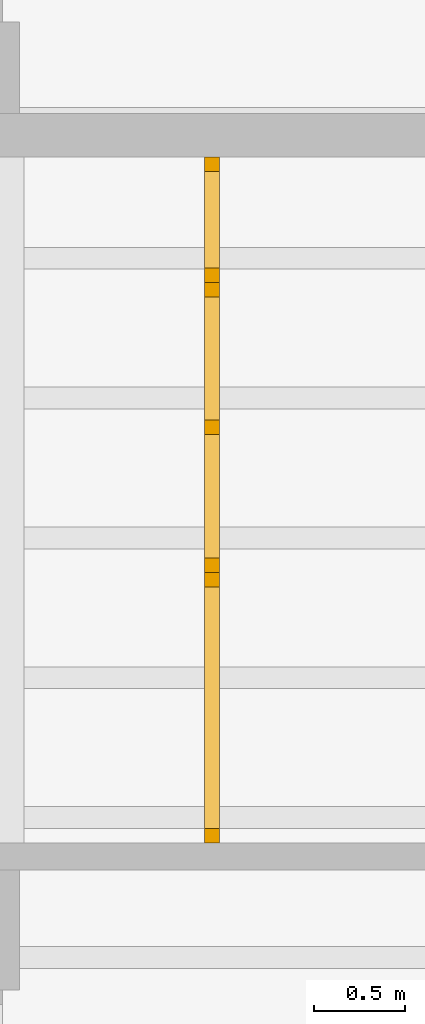
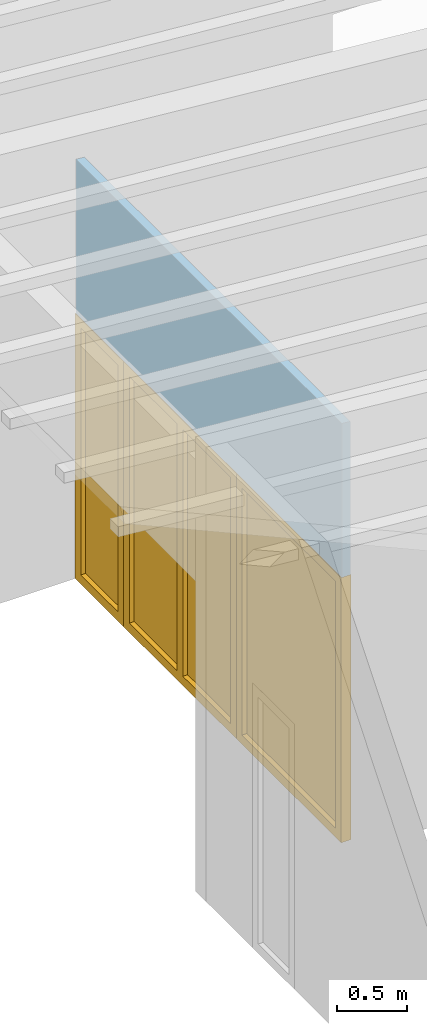
# One storey, part 6 of 13: 2 doors, 1 window, 3 openings, plus 1 element that does not belong to this part.
"""IFC2X3 building model written with IfcOpenShell, lengths in millimetres."""

from ifc_helpers import new_model, entity, si_unit, converted_unit, frame, frame_2d, origin, origin_with_axes, place, context, project, spatial, rectangle, extrude, clip, halfspace, faceted_brep, material, layer, layer_set, layer_usage, type_object, element, fill, save


model = new_model("IFC2X3")

# Units and contexts
model_context = context("Model", 3, precision=1e-05, world=origin())
plan_context = context("Plan", 3, precision=1e-05, world=origin())
ifc_project = project(units=[si_unit("LENGTHUNIT", "METRE", prefix="MILLI"), converted_unit("PLANEANGLEUNIT", "DEGREE", entity("IfcPlaneAngleMeasure", 0.0174532925199433), si_unit("PLANEANGLEUNIT", "RADIAN"), dimensions=[0, 0, 0, 0, 0, 0, 0]), si_unit("AREAUNIT", "SQUARE_METRE"), si_unit("VOLUMEUNIT", "CUBIC_METRE")], contexts=[model_context, plan_context])

# Building, storey
building_placement = place(None, origin())
building = spatial("IfcBuilding", under=ifc_project, at=building_placement, CompositionType="ELEMENT")
storey_placement = place(building_placement, frame((0.0, 0.0, 4770.0), z_axis=(0.0, 0.0, 1.0), x_axis=(1.0, 0.0, 0.0)))
storey = spatial("IfcBuildingStorey", under=building, at=storey_placement, Name="Geschoss", CompositionType="ELEMENT", Elevation=4770.0)

# Wall, openings, doors, window
ifc_material_1 = material(Name="glas")
ifc_layer = layer(ifc_material_1, 70.0)
ifc_layer_set = layer_set([ifc_layer])
ifc_layer_usage = layer_usage(ifc_layer_set, "AXIS2", "POSITIVE", 0.0)
wall_placement = place(storey_placement, frame((22458.3517822139, -4591.5625, 0.0), z_axis=(0.0, 0.0, 1.0), x_axis=(0.0, 1.0, 0.0)))
wall = element("IfcWallStandardCase", 1, at=wall_placement, inside=storey, material=ifc_layer_usage, context=model_context, shape_type="Clipping", body=[
    clip(extrude(rectangle(XDim=3780.0, YDim=70.0, at=frame_2d((1890.0, 35.0), x_axis=(1.0, 0.0))), origin_with_axes(), (0.0, 0.0, 1.0), 3635.62189784294), halfspace(frame((0.0, 0.0, 3629.49769139612), z_axis=(0.0, 0.0871557427476648, -0.996194698091745), x_axis=(1.0, 0.0, 0.0)), True)),
])
opening_1_placement = place(wall_placement, frame((3090.0, 0.0, 0.0), z_axis=(0.0, 1.0, 0.0), x_axis=(0.0, 0.0, 1.0)))
opening_1 = element("IfcOpeningElement", 2, at=opening_1_placement, cuts=wall, ObjectType="Opening", context=model_context, shape_type="SweptSolid", body=[
    extrude(rectangle(XDim=2300.0, YDim=689.999999999996, at=frame_2d((1150.0, 344.999999999998), x_axis=(1.0, 0.0))), origin_with_axes(), (0.0, 0.0, 1.0), 70.0),
])
opening_2_placement = place(wall_placement, frame((0.0, 0.0, 0.0), z_axis=(0.0, 1.0, 0.0), x_axis=(0.0, 0.0, 1.0)))
opening_2 = element("IfcOpeningElement", 3, at=opening_2_placement, cuts=wall, ObjectType="Opening", context=model_context, shape_type="SweptSolid", body=[
    extrude(rectangle(XDim=2300.0, YDim=1490.0, at=frame_2d((1150.0, 745.0), x_axis=(1.0, 0.0))), origin_with_axes(), (0.0, 0.0, 1.0), 70.0),
])
opening_3_placement = place(wall_placement, frame((1490.0, 0.0, 0.0), z_axis=(0.0, 1.0, 0.0), x_axis=(0.0, 0.0, 1.0)))
opening_3 = element("IfcOpeningElement", 4, at=opening_3_placement, cuts=wall, ObjectType="Opening", context=model_context, shape_type="SweptSolid", body=[
    extrude(rectangle(XDim=2300.0, YDim=1600.0, at=frame_2d((1150.0, 800.0), x_axis=(1.0, 0.0))), origin_with_axes(), (0.0, 0.0, 1.0), 70.0),
])
ifc_material_2 = material()
door_style_1 = type_object("IfcDoorStyle", Name="Verglasung 01", ConstructionType="NOTDEFINED", OperationType="USERDEFINED", ParameterTakesPrecedence=False, Sizeable=False)
door_1_placement = place(opening_1_placement, frame((0.0, 0.0, 0.0), z_axis=(1.0, 0.0, 0.0), x_axis=(0.0, 1.0, 0.0)))
door_1 = element("IfcDoor", 5, at=door_1_placement, inside=storey, type_object=door_style_1, material=ifc_material_2, Name="Verglasung 01", OverallHeight=2300.0, OverallWidth=690.0, context=model_context, shape_type="Brep", body=[
    faceted_brep([(609.999999999996, 75.0000000000014, 0.0), (689.999999999996, 75.0000000000014, 0.0), (689.999999999996, 75.0000000000014, 2300.0), (609.999999999996, 75.0000000000014, 2300.0), (689.999999999996, -4.99999999999859, 0.0), (609.999999999996, -4.99999999999859, 0.0), (609.999999999996, -4.99999999999859, 2300.0), (689.999999999996, -4.99999999999859, 2300.0), (689.999999999996, 75.0000000000014, 0.0), (609.999999999996, 75.0000000000014, 0.0), (609.999999999996, -4.99999999999859, 0.0), (689.999999999996, -4.99999999999859, 0.0), (689.999999999996, 75.0000000000014, 2300.0), (689.999999999996, 75.0000000000014, 0.0), (689.999999999996, -4.99999999999859, 0.0), (689.999999999996, -4.99999999999859, 2300.0), (609.999999999996, 75.0000000000014, 2300.0), (689.999999999996, 75.0000000000014, 2300.0), (689.999999999996, -4.99999999999859, 2300.0), (609.999999999996, -4.99999999999859, 2300.0), (609.999999999996, 75.0000000000014, 0.0), (609.999999999996, 75.0000000000014, 2300.0), (609.999999999996, -4.99999999999859, 2300.0), (609.999999999996, -4.99999999999859, 0.0)], [[[0, 1, 2, 3]], [[4, 5, 6, 7]], [[8, 9, 10, 11]], [[12, 13, 14, 15]], [[16, 17, 18, 19]], [[20, 21, 22, 23]]], orient=[[False], [False], [False], [False], [False], [False]]),
    faceted_brep([(80.0, 75.0000000000015, 2300.0), (3.34279265644953e-16, 75.0000000000015, 2300.0), (3.34279265644953e-16, 75.0000000000015, 0.0), (80.0, 75.0000000000015, 0.0), (-4.56414614964456e-15, -4.99999999999854, 2300.0), (80.0, -4.99999999999854, 2300.0), (80.0, -4.99999999999854, 0.0), (-4.56414614964456e-15, -4.99999999999854, 0.0), (3.34279265644953e-16, 75.0000000000015, 2300.0), (80.0, 75.0000000000015, 2300.0), (80.0, -4.99999999999854, 2300.0), (-4.56414614964456e-15, -4.99999999999854, 2300.0), (3.34279265644953e-16, 75.0000000000015, 0.0), (3.34279265644953e-16, 75.0000000000015, 2300.0), (-4.56414614964456e-15, -4.99999999999854, 2300.0), (-4.56414614964456e-15, -4.99999999999854, 0.0), (80.0, 75.0000000000015, 0.0), (3.34279265644953e-16, 75.0000000000015, 0.0), (-4.56414614964456e-15, -4.99999999999854, 0.0), (80.0, -4.99999999999854, 0.0), (80.0, 75.0000000000015, 2300.0), (80.0, 75.0000000000015, 0.0), (80.0, -4.99999999999854, 0.0), (80.0, -4.99999999999854, 2300.0)], [[[0, 1, 2, 3]], [[4, 5, 6, 7]], [[8, 9, 10, 11]], [[12, 13, 14, 15]], [[16, 17, 18, 19]], [[20, 21, 22, 23]]], orient=[[False], [False], [False], [False], [False], [False]]),
    faceted_brep([(609.999999999996, 75.0000000000014, 2220.0), (609.999999999996, 75.0000000000014, 2300.0), (80.0, 75.0000000000015, 2300.0), (80.0, 75.0000000000015, 2220.0), (609.999999999996, -4.99999999999858, 2300.0), (609.999999999996, -4.99999999999858, 2220.0), (80.0, -4.99999999999854, 2220.0), (80.0, -4.99999999999854, 2300.0), (609.999999999996, 75.0000000000014, 2300.0), (609.999999999996, 75.0000000000014, 2220.0), (609.999999999996, -4.99999999999858, 2220.0), (609.999999999996, -4.99999999999858, 2300.0), (80.0, 75.0000000000015, 2300.0), (609.999999999996, 75.0000000000014, 2300.0), (609.999999999996, -4.99999999999858, 2300.0), (80.0, -4.99999999999854, 2300.0), (80.0, 75.0000000000015, 2220.0), (80.0, 75.0000000000015, 2300.0), (80.0, -4.99999999999854, 2300.0), (80.0, -4.99999999999854, 2220.0), (609.999999999996, 75.0000000000014, 2220.0), (80.0, 75.0000000000015, 2220.0), (80.0, -4.99999999999854, 2220.0), (609.999999999996, -4.99999999999858, 2220.0)], [[[0, 1, 2, 3]], [[4, 5, 6, 7]], [[8, 9, 10, 11]], [[12, 13, 14, 15]], [[16, 17, 18, 19]], [[20, 21, 22, 23]]], orient=[[False], [False], [False], [False], [False], [False]]),
    faceted_brep([(80.0, 75.0000000000015, 80.0), (80.0, 75.0000000000015, 0.0), (609.999999999996, 75.0000000000014, 0.0), (609.999999999996, 75.0000000000014, 80.0), (80.0, -4.99999999999854, 0.0), (80.0, -4.99999999999854, 80.0), (609.999999999996, -4.99999999999858, 80.0), (609.999999999996, -4.99999999999858, 0.0), (80.0, 75.0000000000015, 0.0), (80.0, 75.0000000000015, 80.0), (80.0, -4.99999999999854, 80.0), (80.0, -4.99999999999854, 0.0), (609.999999999996, 75.0000000000014, 0.0), (80.0, 75.0000000000015, 0.0), (80.0, -4.99999999999854, 0.0), (609.999999999996, -4.99999999999858, 0.0), (609.999999999996, 75.0000000000014, 80.0), (609.999999999996, 75.0000000000014, 0.0), (609.999999999996, -4.99999999999858, 0.0), (609.999999999996, -4.99999999999858, 80.0), (80.0, 75.0000000000015, 80.0), (609.999999999996, 75.0000000000014, 80.0), (609.999999999996, -4.99999999999858, 80.0), (80.0, -4.99999999999854, 80.0)], [[[0, 1, 2, 3]], [[4, 5, 6, 7]], [[8, 9, 10, 11]], [[12, 13, 14, 15]], [[16, 17, 18, 19]], [[20, 21, 22, 23]]], orient=[[False], [False], [False], [False], [False], [False]]),
    faceted_brep([(609.999999999996, 35.0000000000014, 80.0), (609.999999999996, 35.0000000000014, 2220.0), (80.0, 35.0000000000015, 2220.0), (80.0, 35.0000000000015, 80.0), (609.999999999996, 34.0000000000014, 80.0), (80.0, 34.0000000000015, 80.0), (80.0, 34.0000000000015, 2220.0), (609.999999999996, 34.0000000000014, 2220.0), (609.999999999996, 35.0000000000014, 80.0), (609.999999999996, 34.0000000000014, 80.0), (609.999999999996, 34.0000000000014, 2220.0), (609.999999999996, 35.0000000000014, 2220.0), (609.999999999996, 35.0000000000014, 2220.0), (609.999999999996, 34.0000000000014, 2220.0), (80.0, 34.0000000000015, 2220.0), (80.0, 35.0000000000015, 2220.0), (80.0, 35.0000000000015, 2220.0), (80.0, 34.0000000000015, 2220.0), (80.0, 34.0000000000015, 80.0), (80.0, 35.0000000000015, 80.0), (80.0, 35.0000000000015, 80.0), (80.0, 34.0000000000015, 80.0), (609.999999999996, 34.0000000000014, 80.0), (609.999999999996, 35.0000000000014, 80.0)], [[[0, 1, 2, 3]], [[4, 5, 6, 7]], [[8, 9, 10, 11]], [[12, 13, 14, 15]], [[16, 17, 18, 19]], [[20, 21, 22, 23]]], orient=[[False], [False], [False], [False], [False], [False]]),
])
fill(opening_1, door_1)
ifc_material_3 = material()
door_style_2 = type_object("IfcDoorStyle", Name="m", ConstructionType="NOTDEFINED", OperationType="USERDEFINED", ParameterTakesPrecedence=False, Sizeable=False)
door_2_placement = place(opening_2_placement, frame((0.0, 0.0, 0.0), z_axis=(1.0, 0.0, 0.0), x_axis=(0.0, 1.0, 0.0)))
door_2 = element("IfcDoor", 6, at=door_2_placement, inside=storey, type_object=door_style_2, material=ifc_material_3, Name="m", OverallHeight=2300.0, OverallWidth=1490.0, context=model_context, shape_type="Brep", body=[
    faceted_brep([(1410.0, 75.0000000000014, 0.0), (1490.0, 75.0000000000014, 0.0), (1490.0, 75.0000000000014, 2300.0), (1410.0, 75.0000000000014, 2300.0), (1490.0, -4.99999999999864, 0.0), (1410.0, -4.99999999999864, 0.0), (1410.0, -4.99999999999864, 2300.0), (1490.0, -4.99999999999864, 2300.0), (1490.0, 75.0000000000014, 0.0), (1410.0, 75.0000000000014, 0.0), (1410.0, -4.99999999999864, 0.0), (1490.0, -4.99999999999864, 0.0), (1490.0, 75.0000000000014, 2300.0), (1490.0, 75.0000000000014, 0.0), (1490.0, -4.99999999999864, 0.0), (1490.0, -4.99999999999864, 2300.0), (1410.0, 75.0000000000014, 2300.0), (1490.0, 75.0000000000014, 2300.0), (1490.0, -4.99999999999864, 2300.0), (1410.0, -4.99999999999864, 2300.0), (1410.0, 75.0000000000014, 0.0), (1410.0, 75.0000000000014, 2300.0), (1410.0, -4.99999999999864, 2300.0), (1410.0, -4.99999999999864, 0.0)], [[[0, 1, 2, 3]], [[4, 5, 6, 7]], [[8, 9, 10, 11]], [[12, 13, 14, 15]], [[16, 17, 18, 19]], [[20, 21, 22, 23]]], orient=[[False], [False], [False], [False], [False], [False]]),
    faceted_brep([(80.0, 75.0000000000015, 2300.0), (3.34279265644953e-16, 75.0000000000015, 2300.0), (3.34279265644953e-16, 75.0000000000015, 0.0), (80.0, 75.0000000000015, 0.0), (-4.56414614964456e-15, -4.99999999999854, 2300.0), (80.0, -4.99999999999854, 2300.0), (80.0, -4.99999999999854, 0.0), (-4.56414614964456e-15, -4.99999999999854, 0.0), (3.34279265644953e-16, 75.0000000000015, 2300.0), (80.0, 75.0000000000015, 2300.0), (80.0, -4.99999999999854, 2300.0), (-4.56414614964456e-15, -4.99999999999854, 2300.0), (3.34279265644953e-16, 75.0000000000015, 0.0), (3.34279265644953e-16, 75.0000000000015, 2300.0), (-4.56414614964456e-15, -4.99999999999854, 2300.0), (-4.56414614964456e-15, -4.99999999999854, 0.0), (80.0, 75.0000000000015, 0.0), (3.34279265644953e-16, 75.0000000000015, 0.0), (-4.56414614964456e-15, -4.99999999999854, 0.0), (80.0, -4.99999999999854, 0.0), (80.0, 75.0000000000015, 2300.0), (80.0, 75.0000000000015, 0.0), (80.0, -4.99999999999854, 0.0), (80.0, -4.99999999999854, 2300.0)], [[[0, 1, 2, 3]], [[4, 5, 6, 7]], [[8, 9, 10, 11]], [[12, 13, 14, 15]], [[16, 17, 18, 19]], [[20, 21, 22, 23]]], orient=[[False], [False], [False], [False], [False], [False]]),
    faceted_brep([(1410.0, 75.0000000000014, 2220.0), (1410.0, 75.0000000000014, 2300.0), (80.0, 75.0000000000015, 2300.0), (80.0, 75.0000000000015, 2220.0), (1410.0, -4.99999999999862, 2300.0), (1410.0, -4.99999999999862, 2220.0), (80.0, -4.99999999999854, 2220.0), (80.0, -4.99999999999854, 2300.0), (1410.0, 75.0000000000014, 2300.0), (1410.0, 75.0000000000014, 2220.0), (1410.0, -4.99999999999862, 2220.0), (1410.0, -4.99999999999862, 2300.0), (80.0, 75.0000000000015, 2300.0), (1410.0, 75.0000000000014, 2300.0), (1410.0, -4.99999999999862, 2300.0), (80.0, -4.99999999999854, 2300.0), (80.0, 75.0000000000015, 2220.0), (80.0, 75.0000000000015, 2300.0), (80.0, -4.99999999999854, 2300.0), (80.0, -4.99999999999854, 2220.0), (1410.0, 75.0000000000014, 2220.0), (80.0, 75.0000000000015, 2220.0), (80.0, -4.99999999999854, 2220.0), (1410.0, -4.99999999999862, 2220.0)], [[[0, 1, 2, 3]], [[4, 5, 6, 7]], [[8, 9, 10, 11]], [[12, 13, 14, 15]], [[16, 17, 18, 19]], [[20, 21, 22, 23]]], orient=[[False], [False], [False], [False], [False], [False]]),
    faceted_brep([(80.0, 75.0000000000015, 80.0), (80.0, 75.0000000000015, 0.0), (1410.0, 75.0000000000014, 0.0), (1410.0, 75.0000000000014, 80.0), (80.0, -4.99999999999854, 0.0), (80.0, -4.99999999999854, 80.0), (1410.0, -4.99999999999862, 80.0), (1410.0, -4.99999999999862, 0.0), (80.0, 75.0000000000015, 0.0), (80.0, 75.0000000000015, 80.0), (80.0, -4.99999999999854, 80.0), (80.0, -4.99999999999854, 0.0), (1410.0, 75.0000000000014, 0.0), (80.0, 75.0000000000015, 0.0), (80.0, -4.99999999999854, 0.0), (1410.0, -4.99999999999862, 0.0), (1410.0, 75.0000000000014, 80.0), (1410.0, 75.0000000000014, 0.0), (1410.0, -4.99999999999862, 0.0), (1410.0, -4.99999999999862, 80.0), (80.0, 75.0000000000015, 80.0), (1410.0, 75.0000000000014, 80.0), (1410.0, -4.99999999999862, 80.0), (80.0, -4.99999999999854, 80.0)], [[[0, 1, 2, 3]], [[4, 5, 6, 7]], [[8, 9, 10, 11]], [[12, 13, 14, 15]], [[16, 17, 18, 19]], [[20, 21, 22, 23]]], orient=[[False], [False], [False], [False], [False], [False]]),
    faceted_brep([(1410.0, 35.0000000000014, 80.0), (1410.0, 35.0000000000014, 2220.0), (80.0, 35.0000000000015, 2220.0), (80.0, 35.0000000000015, 80.0), (1410.0, 34.0000000000014, 80.0), (80.0, 34.0000000000015, 80.0), (80.0, 34.0000000000015, 2220.0), (1410.0, 34.0000000000014, 2220.0), (1410.0, 35.0000000000014, 80.0), (1410.0, 34.0000000000014, 80.0), (1410.0, 34.0000000000014, 2220.0), (1410.0, 35.0000000000014, 2220.0), (1410.0, 35.0000000000014, 2220.0), (1410.0, 34.0000000000014, 2220.0), (80.0, 34.0000000000015, 2220.0), (80.0, 35.0000000000015, 2220.0), (80.0, 35.0000000000015, 2220.0), (80.0, 34.0000000000015, 2220.0), (80.0, 34.0000000000015, 80.0), (80.0, 35.0000000000015, 80.0), (80.0, 35.0000000000015, 80.0), (80.0, 34.0000000000015, 80.0), (1410.0, 34.0000000000014, 80.0), (1410.0, 35.0000000000014, 80.0)], [[[0, 1, 2, 3]], [[4, 5, 6, 7]], [[8, 9, 10, 11]], [[12, 13, 14, 15]], [[16, 17, 18, 19]], [[20, 21, 22, 23]]], orient=[[False], [False], [False], [False], [False], [False]]),
])
fill(opening_2, door_2)
ifc_material_4 = material()
window_placement = place(opening_3_placement, frame((0.0, 0.0, 0.0), z_axis=(1.0, 0.0, 0.0), x_axis=(0.0, 1.0, 0.0)))
window = element("IfcWindow", 7, at=window_placement, inside=storey, material=ifc_material_4, Name="m", OverallHeight=2300.0, OverallWidth=1600.0, context=model_context, shape_type="Brep", body=[
    faceted_brep([(1520.0, 75.0000000000014, 0.0), (1600.0, 75.0000000000014, 0.0), (1600.0, 75.0000000000014, 2300.0), (1520.0, 75.0000000000014, 2300.0), (1600.0, -4.99999999999865, 0.0), (1520.0, -4.99999999999865, 0.0), (1520.0, -4.99999999999865, 2300.0), (1600.0, -4.99999999999865, 2300.0), (1600.0, 75.0000000000014, 0.0), (1520.0, 75.0000000000014, 0.0), (1520.0, -4.99999999999865, 0.0), (1600.0, -4.99999999999865, 0.0), (1600.0, 75.0000000000014, 2300.0), (1600.0, 75.0000000000014, 0.0), (1600.0, -4.99999999999865, 0.0), (1600.0, -4.99999999999865, 2300.0), (1520.0, 75.0000000000014, 2300.0), (1600.0, 75.0000000000014, 2300.0), (1600.0, -4.99999999999865, 2300.0), (1520.0, -4.99999999999865, 2300.0), (1520.0, 75.0000000000014, 0.0), (1520.0, 75.0000000000014, 2300.0), (1520.0, -4.99999999999865, 2300.0), (1520.0, -4.99999999999865, 0.0)], [[[0, 1, 2, 3]], [[4, 5, 6, 7]], [[8, 9, 10, 11]], [[12, 13, 14, 15]], [[16, 17, 18, 19]], [[20, 21, 22, 23]]], orient=[[False], [False], [False], [False], [False], [False]]),
    faceted_brep([(80.0, 75.0000000000015, 2300.0), (3.34279265644953e-16, 75.0000000000015, 2300.0), (3.34279265644953e-16, 75.0000000000015, 0.0), (80.0, 75.0000000000015, 0.0), (-4.56414614964456e-15, -4.99999999999854, 2300.0), (80.0, -4.99999999999854, 2300.0), (80.0, -4.99999999999854, 0.0), (-4.56414614964456e-15, -4.99999999999854, 0.0), (3.34279265644953e-16, 75.0000000000015, 2300.0), (80.0, 75.0000000000015, 2300.0), (80.0, -4.99999999999854, 2300.0), (-4.56414614964456e-15, -4.99999999999854, 2300.0), (3.34279265644953e-16, 75.0000000000015, 0.0), (3.34279265644953e-16, 75.0000000000015, 2300.0), (-4.56414614964456e-15, -4.99999999999854, 2300.0), (-4.56414614964456e-15, -4.99999999999854, 0.0), (80.0, 75.0000000000015, 0.0), (3.34279265644953e-16, 75.0000000000015, 0.0), (-4.56414614964456e-15, -4.99999999999854, 0.0), (80.0, -4.99999999999854, 0.0), (80.0, 75.0000000000015, 2300.0), (80.0, 75.0000000000015, 0.0), (80.0, -4.99999999999854, 0.0), (80.0, -4.99999999999854, 2300.0)], [[[0, 1, 2, 3]], [[4, 5, 6, 7]], [[8, 9, 10, 11]], [[12, 13, 14, 15]], [[16, 17, 18, 19]], [[20, 21, 22, 23]]], orient=[[False], [False], [False], [False], [False], [False]]),
    faceted_brep([(80.0, 75.0000000000015, 80.0), (80.0, 75.0000000000015, 0.0), (1520.0, 75.0000000000014, 0.0), (1520.0, 75.0000000000014, 80.0), (80.0, -4.99999999999854, 0.0), (80.0, -4.99999999999854, 80.0), (1520.0, -4.99999999999864, 80.0), (1520.0, -4.99999999999864, 0.0), (80.0, 75.0000000000015, 0.0), (80.0, 75.0000000000015, 80.0), (80.0, -4.99999999999854, 80.0), (80.0, -4.99999999999854, 0.0), (1520.0, 75.0000000000014, 0.0), (80.0, 75.0000000000015, 0.0), (80.0, -4.99999999999854, 0.0), (1520.0, -4.99999999999864, 0.0), (1520.0, 75.0000000000014, 80.0), (1520.0, 75.0000000000014, 0.0), (1520.0, -4.99999999999864, 0.0), (1520.0, -4.99999999999864, 80.0), (80.0, 75.0000000000015, 80.0), (1520.0, 75.0000000000014, 80.0), (1520.0, -4.99999999999864, 80.0), (80.0, -4.99999999999854, 80.0)], [[[0, 1, 2, 3]], [[4, 5, 6, 7]], [[8, 9, 10, 11]], [[12, 13, 14, 15]], [[16, 17, 18, 19]], [[20, 21, 22, 23]]], orient=[[False], [False], [False], [False], [False], [False]]),
    faceted_brep([(1520.0, 75.0000000000014, 2220.0), (1520.0, 75.0000000000014, 2300.0), (80.0, 75.0000000000015, 2300.0), (80.0, 75.0000000000015, 2220.0), (1520.0, -4.99999999999864, 2300.0), (1520.0, -4.99999999999864, 2220.0), (80.0, -4.99999999999854, 2220.0), (80.0, -4.99999999999854, 2300.0), (1520.0, 75.0000000000014, 2300.0), (1520.0, 75.0000000000014, 2220.0), (1520.0, -4.99999999999864, 2220.0), (1520.0, -4.99999999999864, 2300.0), (80.0, 75.0000000000015, 2300.0), (1520.0, 75.0000000000014, 2300.0), (1520.0, -4.99999999999864, 2300.0), (80.0, -4.99999999999854, 2300.0), (80.0, 75.0000000000015, 2220.0), (80.0, 75.0000000000015, 2300.0), (80.0, -4.99999999999854, 2300.0), (80.0, -4.99999999999854, 2220.0), (1520.0, 75.0000000000014, 2220.0), (80.0, 75.0000000000015, 2220.0), (80.0, -4.99999999999854, 2220.0), (1520.0, -4.99999999999864, 2220.0)], [[[0, 1, 2, 3]], [[4, 5, 6, 7]], [[8, 9, 10, 11]], [[12, 13, 14, 15]], [[16, 17, 18, 19]], [[20, 21, 22, 23]]], orient=[[False], [False], [False], [False], [False], [False]]),
    faceted_brep([(760.0, 75.0000000000014, 80.0), (840.0, 75.0000000000014, 80.0), (840.0, 75.0000000000014, 2220.0), (760.0, 75.0000000000014, 2220.0), (840.0, -4.99999999999861, 80.0), (760.0, -4.99999999999859, 80.0), (760.0, -4.99999999999859, 2220.0), (840.0, -4.99999999999861, 2220.0), (840.0, 75.0000000000014, 80.0), (760.0, 75.0000000000014, 80.0), (760.0, -4.99999999999859, 80.0), (840.0, -4.99999999999861, 80.0), (840.0, 75.0000000000014, 2220.0), (840.0, 75.0000000000014, 80.0), (840.0, -4.99999999999861, 80.0), (840.0, -4.99999999999861, 2220.0), (760.0, 75.0000000000014, 2220.0), (840.0, 75.0000000000014, 2220.0), (840.0, -4.99999999999861, 2220.0), (760.0, -4.99999999999859, 2220.0), (760.0, 75.0000000000014, 80.0), (760.0, 75.0000000000014, 2220.0), (760.0, -4.99999999999859, 2220.0), (760.0, -4.99999999999859, 80.0)], [[[0, 1, 2, 3]], [[4, 5, 6, 7]], [[8, 9, 10, 11]], [[12, 13, 14, 15]], [[16, 17, 18, 19]], [[20, 21, 22, 23]]], orient=[[False], [False], [False], [False], [False], [False]]),
    faceted_brep([(80.0, 35.0000000000015, 2220.0), (80.0, 35.0000000000015, 80.0), (760.0, 35.0000000000014, 80.0), (760.0, 35.0000000000014, 2220.0), (80.0, 34.0000000000015, 2220.0), (760.0, 34.0000000000014, 2220.0), (760.0, 34.0000000000014, 80.0), (80.0, 34.0000000000015, 80.0), (80.0, 35.0000000000015, 2220.0), (80.0, 34.0000000000015, 2220.0), (80.0, 34.0000000000015, 80.0), (80.0, 35.0000000000015, 80.0), (80.0, 35.0000000000015, 80.0), (80.0, 34.0000000000015, 80.0), (760.0, 34.0000000000014, 80.0), (760.0, 35.0000000000014, 80.0), (760.0, 35.0000000000014, 80.0), (760.0, 34.0000000000014, 80.0), (760.0, 34.0000000000014, 2220.0), (760.0, 35.0000000000014, 2220.0), (760.0, 35.0000000000014, 2220.0), (760.0, 34.0000000000014, 2220.0), (80.0, 34.0000000000015, 2220.0), (80.0, 35.0000000000015, 2220.0)], [[[0, 1, 2, 3]], [[4, 5, 6, 7]], [[8, 9, 10, 11]], [[12, 13, 14, 15]], [[16, 17, 18, 19]], [[20, 21, 22, 23]]], orient=[[False], [False], [False], [False], [False], [False]]),
    faceted_brep([(840.0, 35.0000000000014, 2220.0), (840.0, 35.0000000000014, 80.0), (1520.0, 35.0000000000014, 80.0), (1520.0, 35.0000000000014, 2220.0), (840.0, 34.0000000000014, 2220.0), (1520.0, 34.0000000000014, 2220.0), (1520.0, 34.0000000000014, 80.0), (840.0, 34.0000000000014, 80.0), (840.0, 35.0000000000014, 2220.0), (840.0, 34.0000000000014, 2220.0), (840.0, 34.0000000000014, 80.0), (840.0, 35.0000000000014, 80.0), (840.0, 35.0000000000014, 80.0), (840.0, 34.0000000000014, 80.0), (1520.0, 34.0000000000014, 80.0), (1520.0, 35.0000000000014, 80.0), (1520.0, 35.0000000000014, 80.0), (1520.0, 34.0000000000014, 80.0), (1520.0, 34.0000000000014, 2220.0), (1520.0, 35.0000000000014, 2220.0), (1520.0, 35.0000000000014, 2220.0), (1520.0, 34.0000000000014, 2220.0), (840.0, 34.0000000000014, 2220.0), (840.0, 35.0000000000014, 2220.0)], [[[0, 1, 2, 3]], [[4, 5, 6, 7]], [[8, 9, 10, 11]], [[12, 13, 14, 15]], [[16, 17, 18, 19]], [[20, 21, 22, 23]]], orient=[[False], [False], [False], [False], [False], [False]]),
])
fill(opening_3, window)

save(model, "model.ifc")
